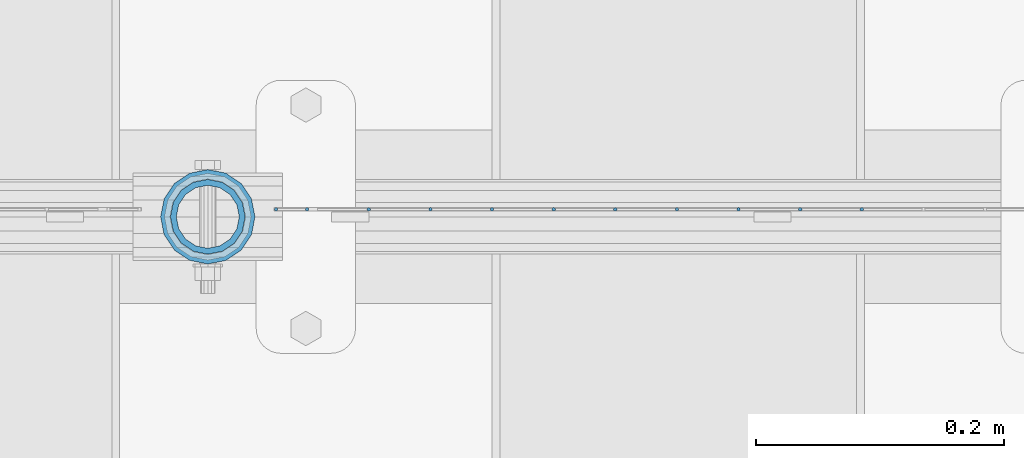
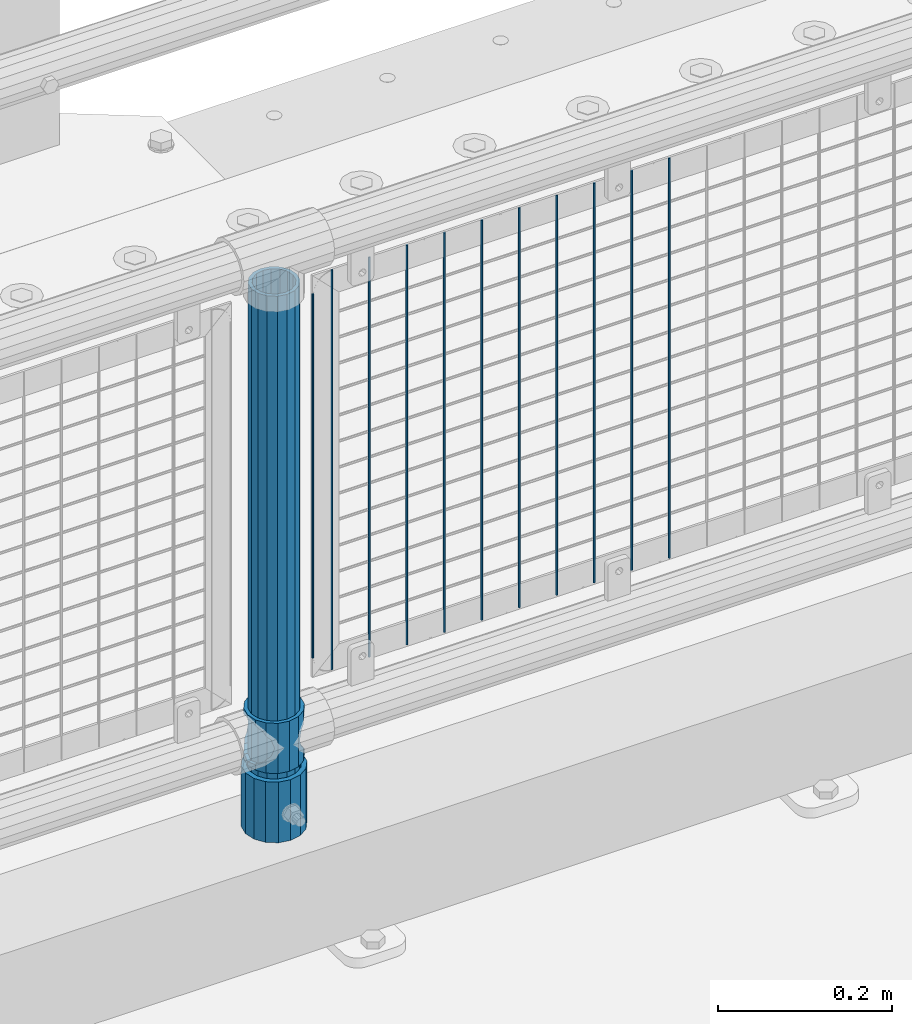
# One storey, part 63 of 208: 14 columns.
"""IFC2X3 building model written with IfcOpenShell, lengths in millimetres."""

from ifc_helpers import new_model, si_unit, frame, origin_with_axes, place, context, subcontext, project, spatial, faceted_brep, material, type_object, element, save


model = new_model("IFC2X3")

# Units and contexts
model_context = context("Model", 3, precision=1e-05, world=origin_with_axes())
body_context = subcontext(model_context, "Body", "Model", "MODEL_VIEW")
ifc_project = project(units=[si_unit("LENGTHUNIT", "METRE", prefix="MILLI"), si_unit("AREAUNIT", "SQUARE_METRE"), si_unit("VOLUMEUNIT", "CUBIC_METRE"), si_unit("MASSUNIT", "GRAM", prefix="KILO"), si_unit("TIMEUNIT", "SECOND"), si_unit("PLANEANGLEUNIT", "RADIAN"), si_unit("SOLIDANGLEUNIT", "STERADIAN"), si_unit("THERMODYNAMICTEMPERATUREUNIT", "DEGREE_CELSIUS"), si_unit("LUMINOUSINTENSITYUNIT", "LUMEN")], contexts=[model_context])

# Site, building, storey
site_placement = place(None, origin_with_axes())
site = spatial("IfcSite", under=ifc_project, at=site_placement, CompositionType="ELEMENT")
building_placement = place(site_placement, origin_with_axes())
building = spatial("IfcBuilding", under=site, at=building_placement, Name="Standard", CompositionType="ELEMENT")
storey_placement = place(building_placement, origin_with_axes())
storey = spatial("IfcBuildingStorey", under=building, at=storey_placement, Name="Undefined", CompositionType="ELEMENT", Elevation=0.0)

# Columns
ifc_material_1 = material()
column_type_1 = type_object("IfcColumnType", PredefinedType="NOTDEFINED")
column_1_placement = place(storey_placement, frame((-37029.0, 4664.5, 168.02), z_axis=(0.0, 1.0, 0.0), x_axis=(0.0, 0.0, 1.0)))
element("IfcColumn", 1, at=column_1_placement, inside=storey, type_object=column_type_1, material=ifc_material_1, context=body_context, shape_type="Brep", body=[
    faceted_brep([(0.0, -31.75, 0.0), (0.0, -29.3331751572332, 12.1501989775916), (85.0, -29.3331751572332, 12.1501989775916), (85.0, -31.75, 0.0), (0.0, -22.4506403026717, 22.4506403026726), (85.0, -22.4506403026717, 22.4506403026726), (0.0, -12.1501989775934, 29.3331751572332), (85.0, -12.1501989775934, 29.3331751572332), (0.0, 0.0, 31.75), (85.0, 0.0, 31.75), (0.0, 12.1501989775934, 29.3331751572332), (85.0, 12.1501989775934, 29.3331751572332), (0.0, 22.4506403026717, 22.4506403026726), (85.0, 22.4506403026717, 22.4506403026726), (0.0, 29.3331751572332, 12.1501989775916), (85.0, 29.3331751572332, 12.1501989775916), (0.0, 31.75, 0.0), (85.0, 31.75, 0.0), (0.0, 29.3331751572332, -12.1501989775916), (85.0, 29.3331751572332, -12.1501989775916), (0.0, 22.4506403026717, -22.4506403026726), (85.0, 22.4506403026717, -22.4506403026726), (0.0, 12.1501989775934, -29.3331751572332), (85.0, 12.1501989775934, -29.3331751572332), (0.0, 0.0, -31.75), (85.0, 0.0, -31.75), (0.0, -12.1501989775934, -29.3331751572332), (85.0, -12.1501989775934, -29.3331751572332), (0.0, -22.4506403026717, -22.4506403026726), (85.0, -22.4506403026717, -22.4506403026726), (0.0, -29.3331751572332, -12.1501989775916), (85.0, -29.3331751572332, -12.1501989775916), (0.0, -38.0499999999993, 0.0), (0.0, -35.1536162120537, -14.5611046014919), (85.0, -35.1536162120537, -14.5611046014919), (85.0, -38.0499999999993, 0.0), (0.0, -26.9054130241493, -26.9054130241484), (85.0, -26.9054130241493, -26.9054130241484), (0.0, -14.5611046014928, -35.1536162120547), (85.0, -14.5611046014928, -35.1536162120547), (0.0, 0.0, -38.0500000000002), (85.0, 0.0, -38.0500000000002), (0.0, 14.5611046014928, -35.1536162120547), (85.0, 14.5611046014928, -35.1536162120547), (0.0, 26.9054130241493, -26.9054130241484), (85.0, 26.9054130241493, -26.9054130241484), (0.0, 35.1536162120537, -14.5611046014919), (85.0, 35.1536162120537, -14.5611046014919), (0.0, 38.0499999999993, 0.0), (85.0, 38.0499999999993, 0.0), (0.0, 35.1536162120537, 14.5611046014919), (85.0, 35.1536162120537, 14.5611046014919), (0.0, 26.9054130241493, 26.9054130241484), (85.0, 26.9054130241493, 26.9054130241484), (0.0, 14.5611046014928, 35.1536162120547), (85.0, 14.5611046014928, 35.1536162120547), (0.0, 0.0, 38.0500000000002), (85.0, 0.0, 38.0500000000002), (0.0, -14.5611046014928, 35.1536162120547), (85.0, -14.5611046014928, 35.1536162120547), (0.0, -26.9054130241493, 26.9054130241484), (85.0, -26.9054130241493, 26.9054130241484), (0.0, -35.1536162120537, 14.5611046014919), (85.0, -35.1536162120537, 14.5611046014919)], [[[0, 1, 2, 3]], [[1, 4, 5, 2]], [[4, 6, 7, 5]], [[6, 8, 9, 7]], [[8, 10, 11, 9]], [[10, 12, 13, 11]], [[12, 14, 15, 13]], [[14, 16, 17, 15]], [[16, 18, 19, 17]], [[18, 20, 21, 19]], [[20, 22, 23, 21]], [[22, 24, 25, 23]], [[24, 26, 27, 25]], [[26, 28, 29, 27]], [[28, 30, 31, 29]], [[30, 0, 3, 31]], [[32, 33, 34, 35]], [[33, 36, 37, 34]], [[36, 38, 39, 37]], [[38, 40, 41, 39]], [[40, 42, 43, 41]], [[42, 44, 45, 43]], [[44, 46, 47, 45]], [[46, 48, 49, 47]], [[48, 50, 51, 49]], [[50, 52, 53, 51]], [[52, 54, 55, 53]], [[54, 56, 57, 55]], [[56, 58, 59, 57]], [[58, 60, 61, 59]], [[60, 62, 63, 61]], [[62, 32, 35, 63]], [[37, 39, 41, 43, 45, 47, 49, 51, 53, 55, 57, 59, 61, 63, 35, 34], [5, 7, 9, 11, 13, 15, 17, 19, 21, 23, 25, 27, 29, 31, 3, 2]], [[62, 60, 58, 56, 54, 52, 50, 48, 46, 44, 42, 40, 38, 36, 33, 32], [30, 28, 26, 24, 22, 20, 18, 16, 14, 12, 10, 8, 6, 4, 1, 0]]]),
])
ifc_material_2 = material(Name="Misc_Undefined")
column_type_2 = type_object("IfcColumnType", PredefinedType="NOTDEFINED")
column_2_placement = place(storey_placement, frame((-37029.0, 4664.5, 263.02), z_axis=(-1.0, 0.0, 0.0), x_axis=(0.0, 0.0, 1.0)))
element("IfcColumn", 2, at=column_2_placement, inside=storey, type_object=column_type_2, material=ifc_material_2, context=body_context, shape_type="Brep", body=[
    faceted_brep([(63.1897438117172, 11.6144421722802, -32.8397438117245), (63.1897438117172, 11.6144421722802, -28.0397438117143), (56.6106908090114, 21.4606908090118, -21.4606908090136), (56.6106908090114, 21.4606908090118, -27.1226768591077), (61.962379517676, 13.4513226476329, -32.4743655677739), (46.7644421722801, 28.0397438117179, -11.6144421722784), (46.7644421722801, 28.0397438117179, -20.0882031229921), (51.531042408003, 24.8548033587067, -24.8548033587067), (35.1500000000015, 30.35, 0.0), (35.1499999999996, 30.3500000000004, -16.6306603983685), (23.5355578277192, 28.0397438117179, -11.6144421722784), (23.5355578277192, 28.0397438117179, -20.0882031229921), (18.7689575919962, 24.8548033587067, -24.8548033587067), (13.6893091909879, 21.4606908090118, -21.4606908090136), (13.6893091909879, 21.4606908090118, -27.1226768591077), (8.33762048232325, 13.4513226476329, -32.4743655677739), (7.11025618828211, 11.6144421722802, -28.0397438117143), (7.11025618828211, 11.6144421722802, -32.8397438117245), (4.79999999999961, 0.0, -30.3499999999985), (4.79999999999961, 0.0, -35.1500000000015), (7.11025618828205, -11.6144421722802, -28.0397438117143), (7.11025618828205, -11.6144421722802, -32.8397438117245), (13.6893091909879, -21.4606908090118, -21.4606908090136), (13.6893091909879, -21.4606908090118, -27.1226768591005), (8.33762048232325, -13.4513226476329, -32.4743655677739), (23.5355578277191, -28.0397438117179, -11.6144421722784), (23.5355578277191, -28.0397438117179, -20.0882031229921), (18.7689575919962, -24.8548033587067, -24.8548033587067), (35.1500000000015, -30.35, 0.0), (35.1499999999996, -30.3500000000004, -16.6306603983685), (46.7644421722801, -28.0397438117179, -11.6144421722784), (46.7644421722801, -28.0397438117179, -20.0882031229921), (51.531042408003, -24.8548033587067, -24.8548033587067), (56.6106908090114, -21.4606908090118, -21.4606908090136), (56.6106908090114, -21.4606908090118, -27.1226768591005), (61.962379517675, -13.4513226476329, -32.4743655677739), (63.1897438117172, -11.6144421722802, -28.0397438117143), (63.1897438117172, -11.6144421722802, -32.8397438117245), (65.4999999999997, 0.0, -30.3499999999985), (65.4999999999997, 0.0, -35.1500000000015), (0.0, -28.0397438117179, -11.6144421722784), (0.0, -30.3500000000004, 0.0), (0.0, -21.4606908090118, -21.4606908090136), (0.0, -11.6144421722802, -28.0397438117143), (0.0, 0.0, -30.3499999999985), (0.0, 11.6144421722802, -28.0397438117143), (0.0, 21.4606908090118, -21.4606908090136), (0.0, 28.0397438117179, -11.6144421722784), (0.0, 30.3500000000004, 0.0), (0.0, 28.0397438117179, 11.6144421722784), (23.5355578277192, 28.0397438117179, 11.6144421722784), (0.0, 21.4606908090118, 21.4606908090136), (13.6893091909879, 21.4606908090118, 21.4606908090136), (0.0, 11.6144421722802, 28.0397438117143), (7.11025618828211, 11.6144421722802, 28.0397438117143), (0.0, 0.0, 30.3499999999985), (4.79999999999961, 0.0, 30.3499999999985), (0.0, -11.6144421722802, 28.0397438117143), (7.11025618828205, -11.6144421722802, 28.0397438117143), (0.0, -21.4606908090118, 21.4606908090136), (13.6893091909879, -21.4606908090118, 21.4606908090136), (0.0, -28.0397438117179, 11.6144421722784), (23.5355578277191, -28.0397438117179, 11.6144421722784), (0.0, -32.4743655677721, 13.4513226476338), (0.0, -35.1499999999996, 0.0), (70.2999999999993, -35.1499999999996, 0.0), (70.2999999999993, -32.4743655677721, 13.4513226476338), (0.0, 13.4513226476329, -32.4743655677739), (0.0, 24.8548033587067, -24.8548033587067), (0.0, 0.0, -35.1499999999996), (0.0, -13.4513226476329, -32.4743655677739), (0.0, -24.8548033587067, -24.8548033587067), (0.0, -24.8548033587067, 24.8548033587067), (0.0, -13.4513226476329, 32.4743655677739), (0.0, 0.0, 35.1499999999996), (0.0, 13.4513226476329, 32.4743655677739), (0.0, 24.8548033587067, 24.8548033587067), (0.0, 32.4743655677721, 13.4513226476338), (0.0, 35.1499999999996, 0.0), (0.0, 32.4743655677721, -13.4513226476338), (0.0, -32.4743655677721, -13.4513226476338), (70.2999999999993, 32.4743655677721, 13.4513226476338), (70.2999999999993, 35.1499999999996, 0.0), (70.2999999999993, 32.4743655677721, -13.4513226476338), (70.2999999999993, 24.8548033587067, -24.8548033587067), (70.2999999999993, 13.4513226476329, -32.4743655677739), (70.2999999999993, 0.0, -35.1500000000015), (70.2999999999993, -13.4513226476329, -32.4743655677739), (70.2999999999993, -24.8548033587067, -24.8548033587067), (70.2999999999993, -32.4743655677721, -13.4513226476338), (70.2999999999993, 28.0397438117179, 11.6144421722784), (70.2999999999993, 21.4606908090118, 21.4606908090136), (56.6106908090114, 21.4606908090118, 21.4606908090136), (46.7644421722801, 28.0397438117179, 11.6144421722784), (70.2999999999993, 11.6144421722802, 28.0397438117143), (63.1897438117172, 11.6144421722802, 28.0397438117143), (70.2999999999993, 0.0, 30.3499999999985), (65.4999999999997, 0.0, 30.3499999999985), (70.2999999999993, -11.6144421722802, 28.0397438117143), (63.1897438117172, -11.6144421722802, 28.0397438117143), (70.2999999999993, -21.4606908090118, 21.4606908090136), (56.6106908090114, -21.4606908090118, 21.4606908090136), (70.2999999999993, -28.0397438117179, 11.6144421722784), (46.7644421722801, -28.0397438117179, 11.6144421722784), (70.2999999999993, -11.6144421722802, -28.0397438117143), (70.2999999999993, 0.0, -30.3499999999985), (70.2999999999993, -21.4606908090118, -21.4606908090136), (70.2999999999993, -28.0397438117179, -11.6144421722784), (70.2999999999993, -30.3500000000004, 0.0), (70.2999999999993, 24.8548033587067, 24.8548033587067), (70.2999999999993, 13.4513226476329, 32.4743655677739), (70.2999999999993, 0.0, 35.1500000000015), (70.2999999999993, -13.4513226476329, 32.4743655677739), (70.2999999999993, -24.8548033587067, 24.8548033587067), (70.2999999999993, 30.3500000000004, 0.0), (70.2999999999993, 28.0397438117179, -11.6144421722784), (70.2999999999993, 21.4606908090118, -21.4606908090136), (70.2999999999993, 11.6144421722802, -28.0397438117143), (61.9623795176756, 13.4513226476329, 32.4743655677739), (51.531042408003, 24.8548033587067, 24.8548033587067), (56.6106908090114, 21.4606908090118, 27.1226768591005), (65.4999999999997, 0.0, 35.1500000000015), (63.1897438117172, 11.6144421722802, 32.8397438117172), (63.1897438117172, -11.6144421722802, 32.8397438117245), (61.962379517675, -13.4513226476329, 32.4743655677739), (56.6106908090114, -21.4606908090118, 27.1226768591077), (51.531042408003, -24.8548033587067, 24.8548033587067), (18.7689575919962, -24.8548033587067, 24.8548033587067), (46.7644421722801, -28.0397438117179, 20.0882031229776), (35.1499999999996, -30.3500000000004, 16.6306603983612), (23.5355578277191, -28.0397438117179, 20.0882031229776), (8.3376204823237, -13.4513226476329, 32.4743655677739), (13.6893091909879, -21.4606908090118, 27.1226768591077), (4.79999999999961, 0.0, 35.1500000000015), (7.11025618828205, -11.6144421722802, 32.8397438117245), (7.11025618828211, 11.6144421722802, 32.8397438117172), (8.3376204823237, 13.4513226476329, 32.4743655677739), (13.6893091909879, 21.4606908090118, 27.1226768591005), (18.7689575919962, 24.8548033587067, 24.8548033587067), (23.5355578277192, 28.0397438117179, 20.0882031229921), (35.1499999999996, 30.3500000000004, 16.6306603983685), (46.7644421722801, 28.0397438117179, 20.0882031229921)], [[[0, 1, 2, 3, 4]], [[3, 2, 5, 6, 7]], [[6, 5, 8, 9]], [[9, 8, 10, 11]], [[12, 11, 10, 13, 14]], [[15, 14, 13, 16, 17]], [[17, 16, 18, 19]], [[19, 18, 20, 21]], [[21, 20, 22, 23, 24]], [[23, 22, 25, 26, 27]], [[26, 25, 28, 29]], [[29, 28, 30, 31]], [[32, 31, 30, 33, 34]], [[35, 34, 33, 36, 37]], [[37, 36, 38, 39]], [[39, 38, 1, 0]], [[40, 41, 28, 25]], [[42, 40, 25, 22]], [[43, 42, 22, 20]], [[44, 43, 20, 18]], [[45, 44, 18, 16]], [[46, 45, 16, 13]], [[47, 46, 13, 10]], [[48, 47, 10, 8]], [[49, 48, 8, 50]], [[51, 49, 50, 52]], [[53, 51, 52, 54]], [[55, 53, 54, 56]], [[57, 55, 56, 58]], [[59, 57, 58, 60]], [[61, 59, 60, 62]], [[41, 61, 62, 28]], [[63, 64, 65, 66]], [[67, 68, 12, 14, 15]], [[69, 67, 15, 17, 19]], [[24, 70, 69, 19, 21]], [[27, 71, 70, 24, 23]], [[63, 72, 73, 74, 75, 76, 77, 78, 79, 68, 67, 69, 70, 71, 80, 64], [40, 42, 43, 44, 45, 46, 47, 48, 49, 51, 53, 55, 57, 59, 61, 41]], [[78, 77, 81, 82]], [[79, 78, 82, 83]], [[9, 11, 12, 68, 79, 83, 84, 7, 6]], [[7, 84, 85, 4, 3]], [[4, 85, 86, 39, 0]], [[87, 88, 32, 34, 35]], [[86, 87, 35, 37, 39]], [[88, 89, 80, 71, 27, 26, 29, 31, 32]], [[64, 80, 89, 65]], [[90, 91, 92, 93]], [[91, 94, 95, 92]], [[94, 96, 97, 95]], [[96, 98, 99, 97]], [[98, 100, 101, 99]], [[100, 102, 103, 101]], [[104, 105, 38, 36]], [[106, 104, 36, 33]], [[107, 106, 33, 30]], [[108, 107, 30, 28]], [[102, 108, 28, 103]], [[88, 87, 86, 85, 84, 83, 82, 81, 109, 110, 111, 112, 113, 66, 65, 89], [100, 98, 96, 94, 91, 90, 114, 115, 116, 117, 105, 104, 106, 107, 108, 102]], [[118, 110, 109, 119, 120]], [[121, 111, 110, 118, 122]], [[112, 111, 121, 123, 124]], [[113, 112, 124, 125, 126]], [[127, 72, 63, 66, 113, 126, 128, 129, 130]], [[131, 73, 72, 127, 132]], [[133, 74, 73, 131, 134]], [[75, 74, 133, 135, 136]], [[76, 75, 136, 137, 138]], [[119, 109, 81, 77, 76, 138, 139, 140, 141]], [[92, 120, 119, 141, 93]], [[95, 122, 118, 120, 92]], [[97, 121, 122, 95]], [[99, 123, 121, 97]], [[101, 125, 124, 123, 99]], [[103, 128, 126, 125, 101]], [[28, 129, 128, 103]], [[62, 130, 129, 28]], [[60, 132, 127, 130, 62]], [[58, 134, 131, 132, 60]], [[56, 133, 134, 58]], [[54, 135, 133, 56]], [[52, 137, 136, 135, 54]], [[50, 139, 138, 137, 52]], [[8, 140, 139, 50]], [[93, 141, 140, 8]], [[114, 90, 93, 8]], [[115, 114, 8, 5]], [[116, 115, 5, 2]], [[117, 116, 2, 1]], [[105, 117, 1, 38]]]),
])
column_type_3 = type_object("IfcColumnType", PredefinedType="NOTDEFINED")
column_3_placement = place(storey_placement, frame((-37029.0, 4664.5, 168.02), z_axis=(-1.0, 0.0, 0.0), x_axis=(0.0, 0.0, 1.0)))
element("IfcColumn", 3, at=column_3_placement, inside=storey, type_object=column_type_3, material=ifc_material_1, context=body_context, shape_type="Brep", body=[
    faceted_brep([(0.0, -25.3500000000004, 0.0), (0.0, -23.4203461491616, 9.70102501045403), (760.0, -23.4203461491616, 9.70102501045403), (760.0, -25.3500000000004, 0.0), (0.0, -17.9251569030794, 17.9251569030785), (760.0, -17.9251569030794, 17.9251569030785), (0.0, -9.70102501045494, 23.4203461491597), (760.0, -9.70102501045494, 23.4203461491597), (0.0, 0.0, 25.3499999999985), (760.0, 0.0, 25.3499999999985), (0.0, 9.70102501045494, 23.4203461491597), (760.0, 9.70102501045494, 23.4203461491597), (0.0, 17.9251569030794, 17.9251569030785), (760.0, 17.9251569030794, 17.9251569030785), (0.0, 23.4203461491616, 9.70102501045403), (760.0, 23.4203461491616, 9.70102501045403), (0.0, 25.3500000000004, 0.0), (760.0, 25.3500000000004, 0.0), (0.0, 23.4203461491616, -9.70102501045403), (760.0, 23.4203461491616, -9.70102501045403), (0.0, 17.9251569030794, -17.9251569030785), (760.0, 17.9251569030794, -17.9251569030785), (0.0, 9.70102501045494, -23.4203461491597), (760.0, 9.70102501045494, -23.4203461491597), (0.0, 0.0, -25.3499999999985), (760.0, 0.0, -25.3499999999985), (0.0, -9.70102501045494, -23.4203461491597), (760.0, -9.70102501045494, -23.4203461491597), (0.0, -17.9251569030794, -17.9251569030785), (760.0, -17.9251569030794, -17.9251569030785), (0.0, -23.4203461491616, -9.70102501045403), (760.0, -23.4203461491616, -9.70102501045403), (0.0, -30.1499999999996, 0.0), (0.0, -27.8549679052148, -11.5379054858058), (760.0, -27.8549679052148, -11.5379054858058), (760.0, -30.1499999999996, 0.0), (0.0, -21.3192694527743, -21.3192694527752), (760.0, -21.3192694527743, -21.3192694527752), (0.0, -11.5379054858076, -27.8549679052157), (760.0, -11.5379054858076, -27.8549679052157), (0.0, 0.0, -30.1500000000015), (760.0, 0.0, -30.1500000000015), (0.0, 11.5379054858076, -27.8549679052157), (760.0, 11.5379054858076, -27.8549679052157), (0.0, 21.3192694527743, -21.3192694527752), (760.0, 21.3192694527743, -21.3192694527752), (0.0, 27.8549679052157, -11.5379054858058), (760.0, 27.8549679052157, -11.5379054858058), (0.0, 30.1499999999996, 0.0), (760.0, 30.1499999999996, 0.0), (0.0, 27.8549679052157, 11.5379054858058), (760.0, 27.8549679052157, 11.5379054858058), (0.0, 21.3192694527743, 21.3192694527752), (760.0, 21.3192694527743, 21.3192694527752), (0.0, 11.5379054858076, 27.8549679052157), (760.0, 11.5379054858076, 27.8549679052157), (0.0, 0.0, 30.1500000000015), (760.0, 0.0, 30.1500000000015), (0.0, -11.5379054858076, 27.8549679052157), (760.0, -11.5379054858076, 27.8549679052157), (0.0, -21.3192694527743, 21.3192694527752), (760.0, -21.3192694527743, 21.3192694527752), (0.0, -27.8549679052157, 11.5379054858058), (760.0, -27.8549679052157, 11.5379054858058)], [[[0, 1, 2, 3]], [[1, 4, 5, 2]], [[4, 6, 7, 5]], [[6, 8, 9, 7]], [[8, 10, 11, 9]], [[10, 12, 13, 11]], [[12, 14, 15, 13]], [[14, 16, 17, 15]], [[16, 18, 19, 17]], [[18, 20, 21, 19]], [[20, 22, 23, 21]], [[22, 24, 25, 23]], [[24, 26, 27, 25]], [[26, 28, 29, 27]], [[28, 30, 31, 29]], [[30, 0, 3, 31]], [[32, 33, 34, 35]], [[33, 36, 37, 34]], [[36, 38, 39, 37]], [[38, 40, 41, 39]], [[40, 42, 43, 41]], [[42, 44, 45, 43]], [[44, 46, 47, 45]], [[46, 48, 49, 47]], [[48, 50, 51, 49]], [[50, 52, 53, 51]], [[52, 54, 55, 53]], [[54, 56, 57, 55]], [[56, 58, 59, 57]], [[58, 60, 61, 59]], [[60, 62, 63, 61]], [[62, 32, 35, 63]], [[37, 39, 41, 43, 45, 47, 49, 51, 53, 55, 57, 59, 61, 63, 35, 34], [5, 7, 9, 11, 13, 15, 17, 19, 21, 23, 25, 27, 29, 31, 3, 2]], [[62, 60, 58, 56, 54, 52, 50, 48, 46, 44, 42, 40, 38, 36, 33, 32], [30, 28, 26, 24, 22, 20, 18, 16, 14, 12, 10, 8, 6, 4, 1, 0]]]),
])
column_type_4 = type_object("IfcColumnType", Name="D3", PredefinedType="NOTDEFINED")
for number, where, z_axis, x_axis in (
    (4, (-36502.105, 4670.5, 353.020000000001), (-1.0, 0.0, 0.0), (0.0, 0.0, 1.0)),
    (5, (-36551.76, 4670.5, 353.020000000001), (-1.0, 0.0, 0.0), (0.0, 0.0, 1.0)),
    (6, (-36601.415, 4670.5, 353.020000000001), (-1.0, 0.0, 0.0), (0.0, 0.0, 1.0)),
    (7, (-36651.07, 4670.5, 353.020000000001), (-1.0, 0.0, 0.0), (0.0, 0.0, 1.0)),
    (8, (-36700.725, 4670.5, 353.020000000001), (-1.0, 0.0, 0.0), (0.0, 0.0, 1.0)),
    (9, (-36750.38, 4670.5, 353.020000000001), (-1.0, 0.0, 0.0), (0.0, 0.0, 1.0)),
    (10, (-36800.035, 4670.5, 353.020000000001), (-1.0, 0.0, 0.0), (0.0, 0.0, 1.0)),
    (11, (-36849.6896551724, 4670.5, 353.020000000001), (-1.0, 0.0, 0.0), (0.0, 0.0, 1.0)),
    (12, (-36899.3448275862, 4670.5, 353.020000000001), (-0.999999999962839, 0.0, 8.62099999968473e-06), (8.62099999949798e-06, 0.0, 0.999999999962839)),
):
    element("IfcColumn", number, at=place(storey_placement, frame(where, z_axis=z_axis, x_axis=x_axis)), inside=storey, type_object=column_type_4, material=ifc_material_2, ObjectType="D3", context=body_context, shape_type="Brep", body=[
        faceted_brep([(0.0, -1.49999999999909, 3.63797880709171e-12), (-7.27595761418343e-12, -0.749999999999091, -1.29903810567669), (560.0, -0.75, -1.29903810567703), (560.0, -1.5, 0.0), (-3.63797880709171e-12, 0.750000000000909, -1.29903810567669), (560.0, 0.75, -1.29903810567703), (0.0, 1.50000000000182, 3.63797880709171e-12), (560.0, 1.5, 0.0), (-3.63797880709171e-12, 0.750000000000909, 1.29903810567669), (560.0, 0.75, 1.29903810567703), (-7.27595761418343e-12, -0.749999999999091, 1.29903810567669), (560.0, -0.75, 1.29903810567703)], [[[0, 1, 2, 3]], [[1, 4, 5, 2]], [[4, 6, 7, 5]], [[6, 8, 9, 7]], [[8, 10, 11, 9]], [[10, 0, 3, 11]], [[5, 7, 9, 11, 3, 2]], [[10, 8, 6, 4, 1, 0]]]),
    ])
column_4_placement = place(storey_placement, frame((-36974.0, 4670.5, 378.020000000001), z_axis=(-1.0, 0.0, 0.0), x_axis=(0.0, 0.0, 1.0)))
element("IfcColumn", 13, at=column_4_placement, inside=storey, type_object=column_type_4, material=ifc_material_2, ObjectType="D3", context=body_context, shape_type="Brep", body=[
    faceted_brep([(0.0, -1.49999999999909, 3.63797880709171e-12), (-7.27595761418343e-12, -0.749999999999091, -1.29903810567669), (510.0, -0.75, -1.29903810567703), (510.0, -1.5, 0.0), (-3.63797880709171e-12, 0.750000000000909, -1.29903810567669), (510.0, 0.75, -1.29903810567703), (0.0, 1.50000000000182, 3.63797880709171e-12), (510.0, 1.5, 0.0), (-3.63797880709171e-12, 0.750000000000909, 1.29903810567669), (510.0, 0.75, 1.29903810567703), (-7.27595761418343e-12, -0.749999999999091, 1.29903810567669), (510.0, -0.75, 1.29903810567703)], [[[0, 1, 2, 3]], [[1, 4, 5, 2]], [[4, 6, 7, 5]], [[6, 8, 9, 7]], [[8, 10, 11, 9]], [[10, 0, 3, 11]], [[5, 7, 9, 11, 3, 2]], [[10, 8, 6, 4, 1, 0]]]),
])
column_5_placement = place(storey_placement, frame((-36949.0, 4670.5, 353.020000000001), z_axis=(-1.0, 0.0, 0.0), x_axis=(0.0, 0.0, 1.0)))
element("IfcColumn", 14, at=column_5_placement, inside=storey, type_object=column_type_4, material=ifc_material_2, ObjectType="D3", context=body_context, shape_type="Brep", body=[
    faceted_brep([(0.0, -1.49999999999909, 3.63797880709171e-12), (-7.27595761418343e-12, -0.749999999999091, -1.29903810567669), (560.0, -0.75, -1.29903810567703), (560.0, -1.5, 0.0), (-3.63797880709171e-12, 0.750000000000909, -1.29903810567669), (560.0, 0.75, -1.29903810567703), (0.0, 1.50000000000182, 3.63797880709171e-12), (560.0, 1.5, 0.0), (-3.63797880709171e-12, 0.750000000000909, 1.29903810567669), (560.0, 0.75, 1.29903810567703), (-7.27595761418343e-12, -0.749999999999091, 1.29903810567669), (560.0, -0.75, 1.29903810567703)], [[[0, 1, 2, 3]], [[1, 4, 5, 2]], [[4, 6, 7, 5]], [[6, 8, 9, 7]], [[8, 10, 11, 9]], [[10, 0, 3, 11]], [[5, 7, 9, 11, 3, 2]], [[10, 8, 6, 4, 1, 0]]]),
])

save(model, "model.ifc")
